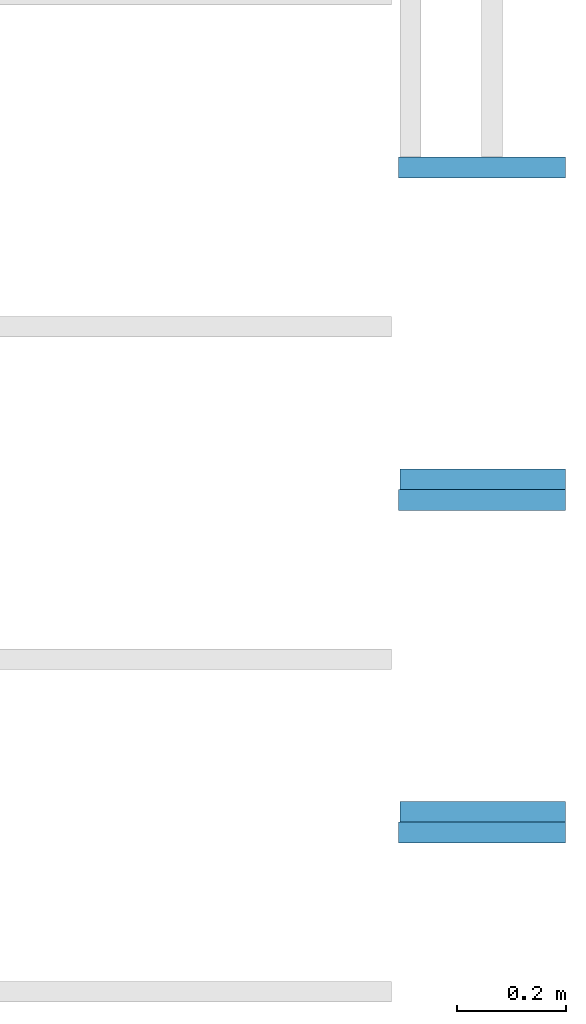
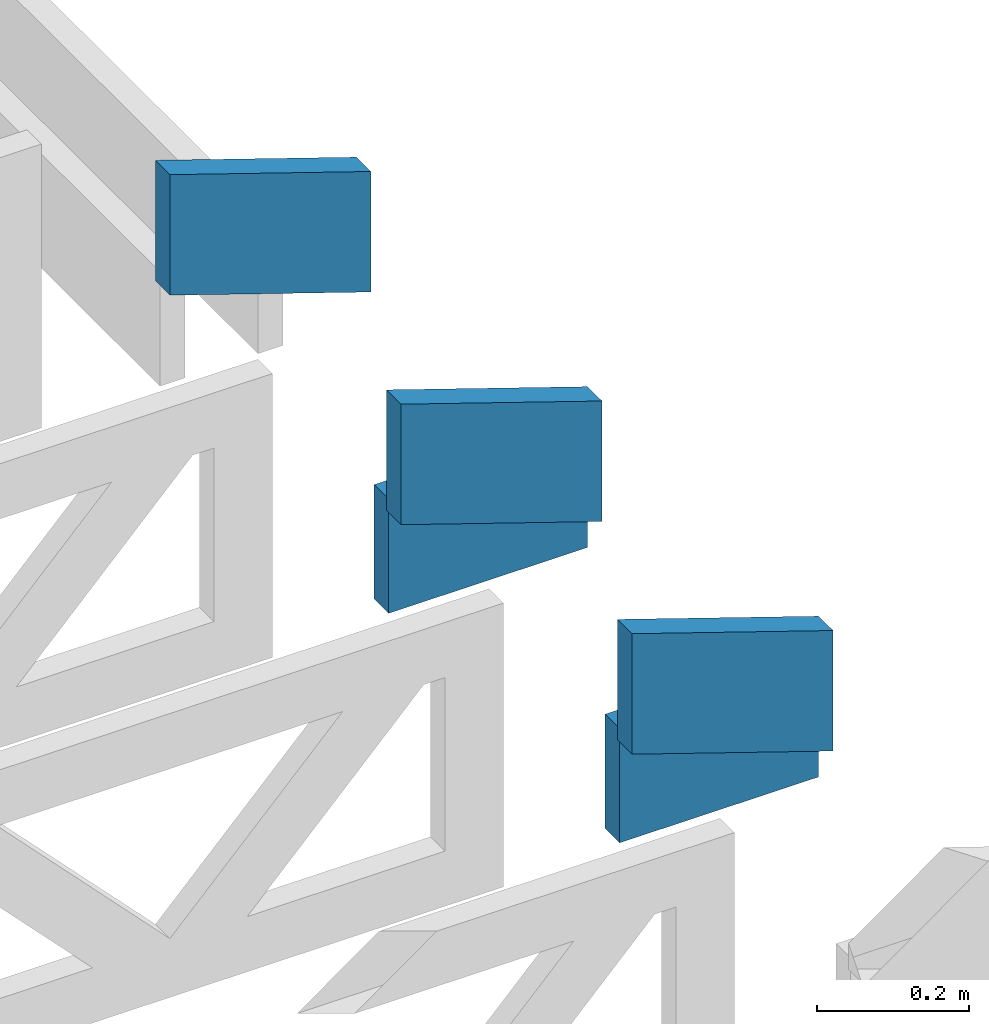
# One storey, part 17 of 18: 5 beams, 2 elements without a shape of their own.
"""IFC4 building model written with IfcOpenShell, lengths in feet."""

from ifc_helpers import new_model, entity, si_unit, converted_unit, derived_unit, direction, frame, frame_2d, origin, origin_2d_with_axis, place, context, subcontext, project, spatial, rectangle, extrude, clip, halfspace, source, transform, mapped, material, material_profile, profile_set, profile_usage, type_object, type_shapes, element, aggregate, save


model = new_model("IFC4")

# Units and contexts
model_context_1 = context("Model", 3, precision=0.0001, world=origin(), true_north=direction((6.12303176911189e-17, 1.0)))
model_context_2 = context("Model", 3, precision=0.0001, world=origin(), true_north=direction((6.12303176911189e-17, 1.0)))
body_context = subcontext(model_context_2, "Body", "Model", "MODEL_VIEW")
ifc_project = project(units=[converted_unit("LENGTHUNIT", "FOOT", entity("IfcRatioMeasure", 0.3048), si_unit("LENGTHUNIT", "METRE"), dimensions=[1, 0, 0, 0, 0, 0, 0]), converted_unit("AREAUNIT", "SQUARE FOOT", entity("IfcRatioMeasure", 0.09290304), si_unit("AREAUNIT", "SQUARE_METRE"), dimensions=[2, 0, 0, 0, 0, 0, 0]), converted_unit("VOLUMEUNIT", "CUBIC FOOT", entity("IfcRatioMeasure", 0.028316846592), si_unit("VOLUMEUNIT", "CUBIC_METRE"), dimensions=[3, 0, 0, 0, 0, 0, 0]), converted_unit("PLANEANGLEUNIT", "DEGREE", entity("IfcRatioMeasure", 0.0174532925199433), si_unit("PLANEANGLEUNIT", "RADIAN"), dimensions=[0, 0, 0, 0, 0, 0, 0]), si_unit("MASSUNIT", "GRAM", prefix="KILO"), derived_unit("MASSDENSITYUNIT", [(si_unit("MASSUNIT", "GRAM", prefix="KILO"), 1), (si_unit("LENGTHUNIT", "METRE"), -3)]), derived_unit("MOMENTOFINERTIAUNIT", [(si_unit("LENGTHUNIT", "METRE"), 4)]), si_unit("TIMEUNIT", "SECOND"), si_unit("FREQUENCYUNIT", "HERTZ"), si_unit("THERMODYNAMICTEMPERATUREUNIT", "DEGREE_CELSIUS"), derived_unit("THERMALTRANSMITTANCEUNIT", [(si_unit("MASSUNIT", "GRAM", prefix="KILO"), 1), (si_unit("THERMODYNAMICTEMPERATUREUNIT", "KELVIN"), -1), (si_unit("TIMEUNIT", "SECOND"), -3)]), derived_unit("VOLUMETRICFLOWRATEUNIT", [(si_unit("LENGTHUNIT", "METRE"), 3), (si_unit("TIMEUNIT", "SECOND"), -1)]), si_unit("ELECTRICCURRENTUNIT", "AMPERE"), si_unit("ELECTRICVOLTAGEUNIT", "VOLT"), si_unit("POWERUNIT", "WATT"), si_unit("FORCEUNIT", "NEWTON"), si_unit("ILLUMINANCEUNIT", "LUX"), si_unit("LUMINOUSFLUXUNIT", "LUMEN"), si_unit("LUMINOUSINTENSITYUNIT", "CANDELA"), derived_unit("USERDEFINED", [(si_unit("MASSUNIT", "GRAM", prefix="KILO"), -1), (si_unit("LENGTHUNIT", "METRE"), -2), (si_unit("TIMEUNIT", "SECOND"), 3), (si_unit("LUMINOUSFLUXUNIT", "LUMEN"), 1)]), derived_unit("LINEARVELOCITYUNIT", [(si_unit("LENGTHUNIT", "METRE"), 1), (si_unit("TIMEUNIT", "SECOND"), -1)]), si_unit("PRESSUREUNIT", "PASCAL"), derived_unit("USERDEFINED", [(si_unit("LENGTHUNIT", "METRE"), -2), (si_unit("MASSUNIT", "GRAM", prefix="KILO"), 1), (si_unit("TIMEUNIT", "SECOND"), -2)]), derived_unit("LINEARFORCEUNIT", [(si_unit("MASSUNIT", "GRAM", prefix="KILO"), 1), (si_unit("LENGTHUNIT", "METRE"), 1), (si_unit("TIMEUNIT", "SECOND"), -2), (si_unit("LENGTHUNIT", "METRE"), -1)]), derived_unit("PLANARFORCEUNIT", [(si_unit("MASSUNIT", "GRAM", prefix="KILO"), 1), (si_unit("LENGTHUNIT", "METRE"), 1), (si_unit("TIMEUNIT", "SECOND"), -2), (si_unit("LENGTHUNIT", "METRE"), -2)])], contexts=[model_context_1])

# Site, building, storey
site_placement = place(None, origin())
site = spatial("IfcSite", under=ifc_project, at=site_placement, CompositionType="ELEMENT")
building_placement = place(site_placement, origin())
building = spatial("IfcBuilding", under=site, at=building_placement, CompositionType="ELEMENT")
storey_placement = place(building_placement, frame((0.0, 0.0, 30.4375000000082)))
storey = spatial("IfcBuildingStorey", under=building, at=storey_placement, Name="ROOF", CompositionType="ELEMENT", Elevation=30.4375000000082)

# Assembly, beams
assembly_1_placement = place(storey_placement, origin())
assembly_1 = element("IfcElementAssembly", 1, at=assembly_1_placement, inside=storey, Name="Structural Beam System:Structural Framing System", ObjectType="Structural Beam System:Structural Framing System", AssemblyPlace="NOTDEFINED", PredefinedType="BEAM_GRID")
ifc_material_1 = material(Name="BOTTOM CHORD OF FIELD FRAMED OVERHANG", Category="Materials")
ifc_material_profile_1 = material_profile(ifc_material_1, rectangle(XDim=0.604166666666667, YDim=0.125000000000011, at=origin_2d_with_axis()), Name="2X8 - BOTTOM CHORD")
ifc_profile_set_1 = profile_set([ifc_material_profile_1], Name="2X8 - BOTTOM CHORD")
ifc_profile_usage_1 = profile_usage(ifc_profile_set_1, cardinal=8)
beam_type_1 = type_object("IfcBeamType", Name="061100 - Wood Framing:2X8 - BOTTOM CHORD", PredefinedType="BEAM", material=ifc_profile_set_1)
shared_shape_1 = source(origin(), body_context, "Body", "SweptSolid", [
    extrude(rectangle(XDim=0.604166666666667, YDim=0.125000000000011, at=origin_2d_with_axis()), frame((-0.497179684451055, 0.0, 0.0), z_axis=(1.0, 0.0, 0.0), x_axis=(0.0, 0.0, -1.0)), (0.0, 0.0, 1.0), 0.99435936890211),
])
type_shapes(beam_type_1, [shared_shape_1])
beam_1_placement = place(assembly_1_placement, frame((-139.855564134411, 952.945268401832, 1.07291666665407)))
beam_1 = element("IfcBeam", 2, at=beam_1_placement, type_object=beam_type_1, material=ifc_profile_usage_1, Name="061100 - Wood Framing:2X8 - BOTTOM CHORD", ObjectType="061100 - Wood Framing:2X8 - BOTTOM CHORD", PredefinedType="BEAM", context=body_context, shape_type="MappedRepresentation", body=[
    mapped(shared_shape_1, transform((0.0, 0.0, 0.0), scale=1.0)),
])
ifc_profile_usage_2 = profile_usage(ifc_profile_set_1, cardinal=8)
beam_2_placement = place(assembly_1_placement, frame((-139.855564134411, 954.945268401832, 1.07291666665407)))
beam_2 = element("IfcBeam", 3, at=beam_2_placement, type_object=beam_type_1, material=ifc_profile_usage_2, Name="061100 - Wood Framing:2X8 - BOTTOM CHORD", ObjectType="061100 - Wood Framing:2X8 - BOTTOM CHORD", PredefinedType="BEAM", context=body_context, shape_type="MappedRepresentation", body=[
    mapped(shared_shape_1, transform((0.0, 0.0, 0.0), scale=1.0)),
])
aggregate(assembly_1, [beam_1, beam_2])

assembly_2_placement = place(storey_placement, origin())
assembly_2 = element("IfcElementAssembly", 4, at=assembly_2_placement, inside=storey, Name="Structural Beam System:Structural Framing System", ObjectType="Structural Beam System:Structural Framing System", AssemblyPlace="NOTDEFINED", PredefinedType="BEAM_GRID")
ifc_material_2 = material(Name="TOP CHORD OF FIELD FRAMED OVERHANG", Category="Materials")
ifc_material_profile_2 = material_profile(ifc_material_2, rectangle(XDim=0.604166666666667, YDim=0.125, at=origin_2d_with_axis()), Name="2X8 TOP CHORD")
ifc_profile_set_2 = profile_set([ifc_material_profile_2], Name="2X8 TOP CHORD")
ifc_profile_usage_3 = profile_usage(ifc_profile_set_2, cardinal=8)
beam_type_2 = type_object("IfcBeamType", Name="Dimension Lumber - Ends:2X8 TOP CHORD", PredefinedType="BEAM", material=ifc_profile_set_2)
shared_shape_2 = source(origin(), body_context, "Body", "Clipping", [
    clip(clip(extrude(rectangle(XDim=0.604166666666671, YDim=0.125, at=frame_2d((-1.52655665885959e-15, 0.0), x_axis=(1.0, 0.0))), frame((-0.529560098375526, 0.0, 0.0), z_axis=(1.0, 0.0, 0.0), x_axis=(0.0, 0.0, -1.0)), (0.0, 0.0, 1.0), 1.26045110526351), halfspace(frame((0.529560098375489, -0.0625000000000025, -0.302083333333339), z_axis=(0.948710608132914, 0.0, -0.316145823973805), x_axis=(0.0, 1.0, 0.0)), False)), halfspace(frame((-0.328229189863038, -0.0625000000000025, 0.302083333333328), z_axis=(-0.948710608132914, 0.0, 0.316145823973805), x_axis=(0.0, 1.0, 0.0)), False)),
])
type_shapes(beam_type_2, [shared_shape_2])
beam_3_placement = place(assembly_2_placement, frame((-139.765291953278, 956.820268401833, 1.43770432947422), z_axis=(0.316227766016836, 0.0, 0.948683298050515), x_axis=(-0.948683298050516, 0.0, 0.316227766016833)))
beam_3 = element("IfcBeam", 5, at=beam_3_placement, type_object=beam_type_2, material=ifc_profile_usage_3, Name="Dimension Lumber - Ends:2X8 TOP CHORD", ObjectType="Dimension Lumber - Ends:2X8 TOP CHORD", PredefinedType="BEAM", context=body_context, shape_type="MappedRepresentation", body=[
    mapped(shared_shape_2, transform((0.0, 0.0, 0.0), scale=1.0)),
])
ifc_profile_usage_4 = profile_usage(ifc_profile_set_2, cardinal=8)
beam_4_placement = place(assembly_2_placement, frame((-139.765291953278, 954.820268401833, 1.43770432947422), z_axis=(0.316227766016839, 0.0, 0.948683298050514), x_axis=(-0.948683298050515, 0.0, 0.316227766016836)))
beam_4 = element("IfcBeam", 6, at=beam_4_placement, type_object=beam_type_2, material=ifc_profile_usage_4, Name="Dimension Lumber - Ends:2X8 TOP CHORD", ObjectType="Dimension Lumber - Ends:2X8 TOP CHORD", PredefinedType="BEAM", context=body_context, shape_type="MappedRepresentation", body=[
    mapped(shared_shape_2, transform((0.0, 0.0, 0.0), scale=1.0)),
])
ifc_profile_usage_5 = profile_usage(ifc_profile_set_2, cardinal=8)
beam_5_placement = place(assembly_2_placement, frame((-139.765291953277, 952.820268401833, 1.43770432947489), z_axis=(0.31622776601683, 0.0, 0.948683298050517), x_axis=(-0.948683298050516, 0.0, 0.316227766016833)))
beam_5 = element("IfcBeam", 7, at=beam_5_placement, type_object=beam_type_2, material=ifc_profile_usage_5, Name="Dimension Lumber - Ends:2X8 TOP CHORD", ObjectType="Dimension Lumber - Ends:2X8 TOP CHORD", PredefinedType="BEAM", context=body_context, shape_type="MappedRepresentation", body=[
    mapped(shared_shape_2, transform((0.0, 0.0, 0.0), scale=1.0)),
])
aggregate(assembly_2, [beam_3, beam_4, beam_5])

save(model, "model.ifc")
